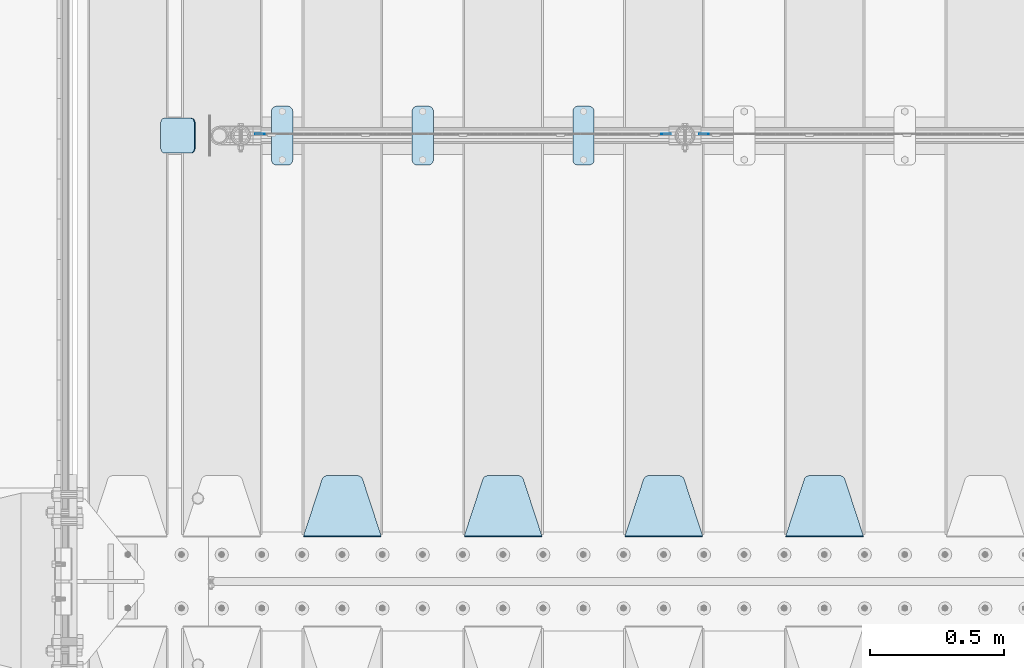
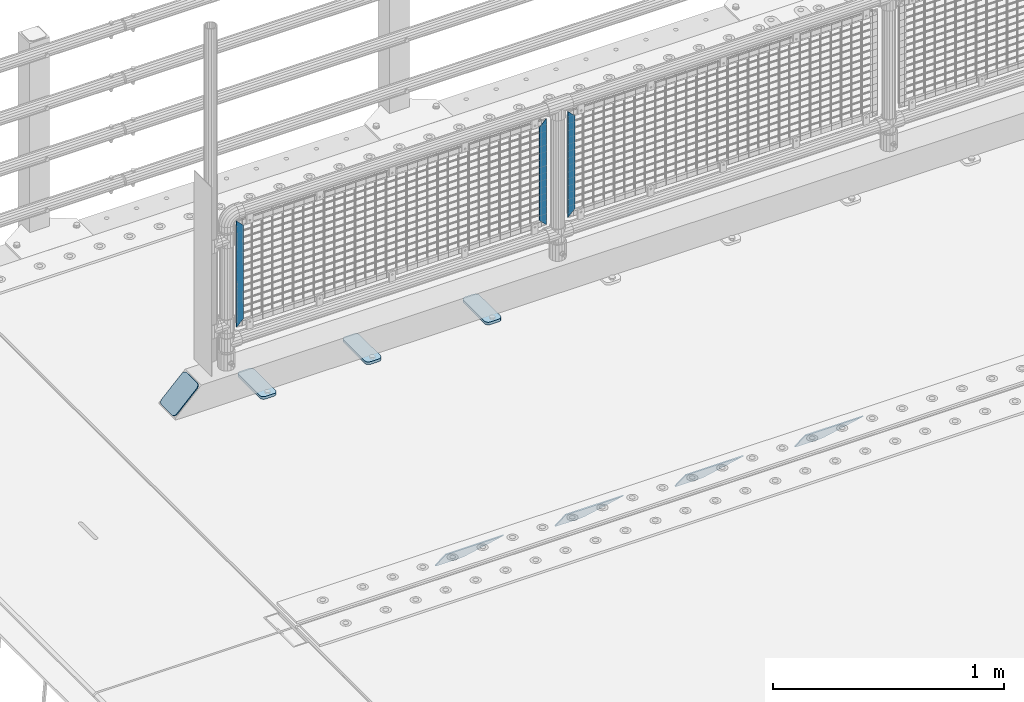
# One storey, part 158 of 193: 11 plates.
"""IFC2X3 building model written with IfcOpenShell, lengths in millimetres."""

import ifcopenshell
import ifcopenshell.guid

model = None  # the IFC model being written
_history = None  # IfcOwnerHistory: only IFC2X3 demands one
_inside = {}  # id of a spatial element -> (the spatial element, [elements in it])
_under = {}  # id of a project, library or spatial element -> (it, [spatial elements below it])
_declared = {}  # id of a project -> (the project, [libraries it declares])
_typed = {}  # id of a type object -> (the type object, [elements of that type])
_made_of = {}  # id of a material, layer set ... -> (it, [elements and type objects made of it])


def new_model(schema):
    """Start an empty IFC model of exactly this schema.

    Asked for "IFC4X3", IfcOpenShell would pick the latest addendum, in which some entities
    have other attributes; the version numbers below select the first issue.
    IFC2X3 requires an IfcOwnerHistory on every rooted entity: one is made here for all.
    """
    global model, _history
    if schema == "IFC4X3":
        model = ifcopenshell.file(schema_version=(4, 3, 0, 0))
    else:
        model = ifcopenshell.file(schema=schema)
    _inside.clear()
    _under.clear()
    _declared.clear()
    _typed.clear()
    _made_of.clear()
    _history = None
    if model.schema == "IFC2X3":
        org = make("IfcOrganization", Name="unknown")
        user = make(
            "IfcPersonAndOrganization",
            ThePerson=make("IfcPerson", FamilyName="unknown"),
            TheOrganization=org,
        )
        app = make(
            "IfcApplication",
            ApplicationDeveloper=org,
            Version="unknown",
            ApplicationFullName="unknown",
            ApplicationIdentifier="unknown",
        )
        _history = make(
            "IfcOwnerHistory",
            OwningUser=user,
            OwningApplication=app,
            ChangeAction="ADDED",
            CreationDate=0,
        )
    return model


def make(cls, **values):
    """One entity of the class cls with the attributes given. An attribute that is None is left unset."""
    return model.create_entity(
        cls, **{name: value for name, value in values.items() if value is not None}
    )


def rooted(cls, **values):
    """An entity with a GlobalId (a new one), such as an element, a storey or a relation."""
    return make(cls, GlobalId=ifcopenshell.guid.new(), OwnerHistory=_history, **values)


def si_unit(unit_type, name, prefix=None):
    """IfcSIUnit, for example si_unit("LENGTHUNIT", "METRE", prefix="MILLI")."""
    return make("IfcSIUnit", UnitType=unit_type, Prefix=prefix, Name=name)


def assignment(units):
    """IfcUnitAssignment: the units of a project."""
    return None if units is None else make("IfcUnitAssignment", Units=units)


def point(xyz):
    """IfcCartesianPoint."""
    return None if xyz is None else make("IfcCartesianPoint", Coordinates=xyz)


def direction(xyz):
    """IfcDirection."""
    return None if xyz is None else make("IfcDirection", DirectionRatios=xyz)


def frame(location, z_axis=None, x_axis=None):
    """IfcAxis2Placement3D, a coordinate frame: its origin and axes. An axis left out is left unset."""
    return make(
        "IfcAxis2Placement3D",
        Location=point(location),
        Axis=direction(z_axis),
        RefDirection=direction(x_axis),
    )


def origin_with_axes():
    """The frame at (0, 0, 0) with the z axis (0, 0, 1) and the x axis (1, 0, 0) written out."""
    return frame((0.0, 0.0, 0.0), z_axis=(0.0, 0.0, 1.0), x_axis=(1.0, 0.0, 0.0))


def place(relative_to, where):
    """IfcLocalPlacement: puts the frame where relative to a parent placement (None: the world)."""
    return make(
        "IfcLocalPlacement", PlacementRelTo=relative_to, RelativePlacement=where
    )


def context(
    kind, dimensions, precision=None, world=None, true_north=None, identifier=None
):
    """IfcGeometricRepresentationContext, for example the 3D "Model" context."""
    return make(
        "IfcGeometricRepresentationContext",
        ContextIdentifier=identifier,
        ContextType=kind,
        CoordinateSpaceDimension=dimensions,
        Precision=precision,
        WorldCoordinateSystem=world,
        TrueNorth=true_north,
    )


def subcontext(parent, identifier, kind, view, scale=None):
    """IfcGeometricRepresentationSubContext, for example "Body" below "Model"."""
    return make(
        "IfcGeometricRepresentationSubContext",
        ContextIdentifier=identifier,
        ContextType=kind,
        ParentContext=parent,
        TargetScale=scale,
        TargetView=view,
    )


def project(units=None, contexts=None):
    """IfcProject with its units and contexts."""
    return rooted(
        "IfcProject",
        Name="project",
        RepresentationContexts=contexts,
        UnitsInContext=assignment(units),
    )


def spatial(cls, under=None, at=None, **own):
    """A site, building, storey or space (cls), placed at a placement, below another one or the project."""
    s = rooted(cls, ObjectPlacement=at, **own)
    if under is not None:
        _under.setdefault(under.id(), (under, []))[1].append(s)
    return s


def faces_of(points, faces, orient=None, outer=None):
    """IfcFace entities. A face is a list of loops; a loop is a list of indices into points, from 0.

    orient and outer hold one flag for each loop. By default every Orientation is true, the
    first loop of a face is its IfcFaceOuterBound and the others are IfcFaceBound.
    """
    made = []
    for i, loops in enumerate(faces):
        bounds = []
        for j, loop in enumerate(loops):
            is_outer = j == 0 if outer is None else outer[i][j]
            bounds.append(
                make(
                    "IfcFaceOuterBound" if is_outer else "IfcFaceBound",
                    Bound=make("IfcPolyLoop", Polygon=[points[k] for k in loop]),
                    Orientation=True if orient is None else orient[i][j],
                )
            )
        made.append(make("IfcFace", Bounds=bounds))
    return made


def faceted_brep(points, faces, orient=None, outer=None, voids=None):
    """IfcFacetedBrep: a solid bounded by flat faces; with voids (closed shells), ...WithVoids."""
    shared = [point(p) for p in points]
    hull = make("IfcClosedShell", CfsFaces=faces_of(shared, faces, orient, outer))
    if voids is None:
        return make("IfcFacetedBrep", Outer=hull)
    return make(
        "IfcFacetedBrepWithVoids",
        Outer=hull,
        Voids=[
            make(cls, CfsFaces=faces_of(shared, fs, o, b)) for cls, fs, o, b in voids
        ],
    )


def shape(context_of_items, identifier, shape_type, items):
    """IfcShapeRepresentation: the items that make up one representation, for example the "Body"."""
    return make(
        "IfcShapeRepresentation",
        ContextOfItems=context_of_items,
        RepresentationIdentifier=identifier,
        RepresentationType=shape_type,
        Items=items,
    )


def material(Name=None, Category=None):
    """IfcMaterial."""
    return make("IfcMaterial", Name=Name, Category=Category)


def made_of(thing, what):
    """Note that an element or type object is made of a material, layer set ...; save() writes the relation."""
    if what is not None:
        _made_of.setdefault(what.id(), (what, []))[1].append(thing)
    return thing


def type_object(cls, material=None, **own):
    """A type object (cls), such as IfcWallType, which elements share."""
    return made_of(rooted(cls, **own), material)


def element(
    cls,
    number,
    at=None,
    inside=None,
    cuts=None,
    type_object=None,
    material=None,
    context=None,
    identifier="Body",
    shape_type=None,
    held_by="IfcProductDefinitionShape",
    body=None,
    shapes=None,
    **own,
):
    """One element of the class cls, such as IfcWall. Its Tag is "e" and its number.

    at: its placement. inside: the storey or other place that contains it. cuts: it is an
    opening in that element (IfcRelVoidsElement). A single representation is given by context,
    identifier, shape_type and body (its items); several are given by shapes. held_by: the class
    of the entity that holds the representations. save() writes the other relations.
    """
    e = rooted(cls, Tag="e%d" % number, ObjectPlacement=at, **own)
    if body is not None:
        shapes = [shape(context, identifier, shape_type, body)]
    if shapes is not None:
        e.Representation = make(held_by, Representations=shapes)
    if inside is not None:
        _inside.setdefault(inside.id(), (inside, []))[1].append(e)
    if cuts is not None:
        rooted(
            "IfcRelVoidsElement", RelatingBuildingElement=cuts, RelatedOpeningElement=e
        )
    if type_object is not None:
        _typed.setdefault(type_object.id(), (type_object, []))[1].append(e)
    return made_of(e, material)


def aggregate(whole, parts):
    """IfcRelAggregates: a whole, such as a stair, and the parts it consists of."""
    return rooted("IfcRelAggregates", RelatingObject=whole, RelatedObjects=parts)


def save(model, path):
    """Write the relations noted so far, then the file.

    IfcRelAggregates (storeys below a building ...), IfcRelContainedInSpatialStructure (elements
    in a storey), IfcRelDefinesByType, IfcRelAssociatesMaterial and IfcRelDeclares: one each for
    every whole, place, type object, material and project.
    """
    for whole, parts in _under.values():
        aggregate(whole, parts)
    for where, things in _inside.values():
        rooted(
            "IfcRelContainedInSpatialStructure",
            RelatedElements=things,
            RelatingStructure=where,
        )
    for kind, things in _typed.values():
        rooted("IfcRelDefinesByType", RelatedObjects=things, RelatingType=kind)
    for what, things in _made_of.values():
        rooted("IfcRelAssociatesMaterial", RelatedObjects=things, RelatingMaterial=what)
    for by, libraries in _declared.values():
        rooted("IfcRelDeclares", RelatingContext=by, RelatedDefinitions=libraries)
    model.write(path)


model = new_model("IFC2X3")

# Units and contexts
model_context = context("Model", 3, precision=1e-05, world=origin_with_axes())
body_context = subcontext(model_context, "Body", "Model", "MODEL_VIEW")
ifc_project = project(units=[si_unit("LENGTHUNIT", "METRE", prefix="MILLI"), si_unit("AREAUNIT", "SQUARE_METRE"), si_unit("VOLUMEUNIT", "CUBIC_METRE"), si_unit("MASSUNIT", "GRAM", prefix="KILO"), si_unit("TIMEUNIT", "SECOND"), si_unit("PLANEANGLEUNIT", "RADIAN"), si_unit("SOLIDANGLEUNIT", "STERADIAN"), si_unit("THERMODYNAMICTEMPERATUREUNIT", "DEGREE_CELSIUS"), si_unit("LUMINOUSINTENSITYUNIT", "LUMEN")], contexts=[model_context])

# Site, building, storey
site_placement = place(None, origin_with_axes())
site = spatial("IfcSite", under=ifc_project, at=site_placement, CompositionType="ELEMENT")
building_placement = place(site_placement, origin_with_axes())
building = spatial("IfcBuilding", under=site, at=building_placement, Name="Standard", CompositionType="ELEMENT")
storey_placement = place(building_placement, origin_with_axes())
storey = spatial("IfcBuildingStorey", under=building, at=storey_placement, Name="Undefined", CompositionType="ELEMENT", Elevation=0.0)

# Plates
ifc_material_1 = material(Name="STEEL/S355N")
plate_type_1 = type_object("IfcPlateType", PredefinedType="NOTDEFINED")
plate_1_placement = place(storey_placement, frame((-39505.0, 27168.232233047, -1.76776695296758), z_axis=(0.0, 0.707106781186547, -0.707106781186548), x_axis=(-1.0, 0.0, 0.0)))
element("IfcPlate", 1, at=plate_1_placement, inside=storey, type_object=plate_type_1, material=ifc_material_1, context=body_context, shape_type="Brep", body=[
    faceted_brep([(0.0, -2.5, 0.0), (69.345504679477, -2.50000000000364, 300.171731424831), (69.345504679477, 2.49999999999636, 300.171731424831), (0.0, 2.5, 0.0), (70.9274061199576, -2.50000000000364, 304.897442415397), (70.9274061199576, 2.49999999999636, 304.897442415397), (73.3818627772307, -2.50000000000364, 309.234538108529), (73.3818627772307, 2.49999999999636, 309.234538108529), (76.6187032999551, -2.50000000000728, 313.023683126103), (76.6187032999551, 2.49999999999636, 313.023683126103), (80.5190132704993, -2.50000000000364, 316.125672595372), (80.5190132704993, 2.49999999999636, 316.125672595368), (84.9395038596849, -2.50000000000364, 318.426546230472), (84.9395038596849, 2.49999999999636, 318.426546230476), (89.7177759439219, -2.50000000000364, 319.841774983273), (89.7177759439219, 2.49999999999636, 319.841774983277), (94.678286292652, -2.50000000000364, 320.319366455074), (94.678286292652, 2.49999999999636, 320.319366455074), (195.321713707348, -2.50000000000364, 320.319366455074), (195.321713707348, 2.49999999999636, 320.319366455074), (200.282224056078, -2.50000000000364, 319.841774983273), (200.282224056078, 2.49999999999636, 319.841774983277), (205.060496140315, -2.50000000000364, 318.426546230472), (205.060496140315, 2.49999999999636, 318.426546230472), (209.480986729501, -2.50000000000364, 316.125672595372), (209.480986729501, 2.49999999999636, 316.125672595368), (213.381296700045, -2.50000000000728, 313.023683126103), (213.381296700045, 2.49999999999272, 313.023683126103), (216.618137222769, -2.50000000000364, 309.234538108525), (216.618137222769, 2.49999999999636, 309.234538108522), (219.072593880042, -2.50000000000364, 304.897442415397), (219.072593880042, 2.49999999999636, 304.897442415397), (220.654495320523, -2.50000000000364, 300.171731424831), (220.654495320523, 2.49999999999636, 300.171731424831), (290.0, -2.50000000000364, 0.0), (290.0, 2.49999999999636, 0.0)], [[[0, 1, 2, 3]], [[1, 4, 5, 2]], [[4, 6, 7, 5]], [[6, 8, 9, 7]], [[8, 10, 11, 9]], [[10, 12, 13, 11]], [[12, 14, 15, 13]], [[14, 16, 17, 15]], [[16, 18, 19, 17]], [[18, 20, 21, 19]], [[20, 22, 23, 21]], [[22, 24, 25, 23]], [[24, 26, 27, 25]], [[26, 28, 29, 27]], [[28, 30, 31, 29]], [[30, 32, 33, 31]], [[32, 34, 35, 33]], [[34, 0, 3, 35]], [[5, 7, 9, 11, 13, 15, 17, 19, 21, 23, 25, 27, 29, 31, 33, 35, 3, 2]], [[34, 32, 30, 28, 26, 24, 22, 20, 18, 16, 14, 12, 10, 8, 6, 4, 1, 0]]]),
])
plate_2_placement = place(storey_placement, frame((-40105.0, 27168.232233047, -1.76776695296758), z_axis=(0.0, 0.707106781186547, -0.707106781186548), x_axis=(-1.0, 0.0, 0.0)))
element("IfcPlate", 2, at=plate_2_placement, inside=storey, type_object=plate_type_1, material=ifc_material_1, context=body_context, shape_type="Brep", body=[
    faceted_brep([(0.0, -2.5, 0.0), (69.345504679477, -2.50000000000364, 300.171731424831), (69.345504679477, 2.49999999999636, 300.171731424831), (0.0, 2.5, 0.0), (70.9274061199576, -2.50000000000364, 304.897442415397), (70.9274061199576, 2.49999999999636, 304.897442415397), (73.3818627772307, -2.50000000000364, 309.234538108529), (73.3818627772307, 2.49999999999636, 309.234538108529), (76.6187032999551, -2.50000000000728, 313.023683126103), (76.6187032999551, 2.49999999999636, 313.023683126103), (80.5190132704993, -2.50000000000364, 316.125672595372), (80.5190132704993, 2.49999999999636, 316.125672595368), (84.9395038596849, -2.50000000000364, 318.426546230472), (84.9395038596849, 2.49999999999636, 318.426546230476), (89.7177759439219, -2.50000000000364, 319.841774983273), (89.7177759439219, 2.49999999999636, 319.841774983277), (94.678286292652, -2.50000000000364, 320.319366455074), (94.678286292652, 2.49999999999636, 320.319366455074), (195.321713707348, -2.50000000000364, 320.319366455074), (195.321713707348, 2.49999999999636, 320.319366455074), (200.282224056078, -2.50000000000364, 319.841774983273), (200.282224056078, 2.49999999999636, 319.841774983277), (205.060496140315, -2.50000000000364, 318.426546230472), (205.060496140315, 2.49999999999636, 318.426546230472), (209.480986729501, -2.50000000000364, 316.125672595372), (209.480986729501, 2.49999999999636, 316.125672595368), (213.381296700045, -2.50000000000728, 313.023683126103), (213.381296700045, 2.49999999999272, 313.023683126103), (216.618137222769, -2.50000000000364, 309.234538108525), (216.618137222769, 2.49999999999636, 309.234538108522), (219.072593880042, -2.50000000000364, 304.897442415397), (219.072593880042, 2.49999999999636, 304.897442415397), (220.654495320523, -2.50000000000364, 300.171731424831), (220.654495320523, 2.49999999999636, 300.171731424831), (290.0, -2.50000000000364, 0.0), (290.0, 2.49999999999636, 0.0)], [[[0, 1, 2, 3]], [[1, 4, 5, 2]], [[4, 6, 7, 5]], [[6, 8, 9, 7]], [[8, 10, 11, 9]], [[10, 12, 13, 11]], [[12, 14, 15, 13]], [[14, 16, 17, 15]], [[16, 18, 19, 17]], [[18, 20, 21, 19]], [[20, 22, 23, 21]], [[22, 24, 25, 23]], [[24, 26, 27, 25]], [[26, 28, 29, 27]], [[28, 30, 31, 29]], [[30, 32, 33, 31]], [[32, 34, 35, 33]], [[34, 0, 3, 35]], [[5, 7, 9, 11, 13, 15, 17, 19, 21, 23, 25, 27, 29, 31, 33, 35, 3, 2]], [[34, 32, 30, 28, 26, 24, 22, 20, 18, 16, 14, 12, 10, 8, 6, 4, 1, 0]]]),
])
plate_3_placement = place(storey_placement, frame((-40705.0, 27168.232233047, -1.76776695296758), z_axis=(0.0, 0.707106781186547, -0.707106781186548), x_axis=(-1.0, 0.0, 0.0)))
element("IfcPlate", 3, at=plate_3_placement, inside=storey, type_object=plate_type_1, material=ifc_material_1, context=body_context, shape_type="Brep", body=[
    faceted_brep([(0.0, -2.5, 0.0), (69.345504679477, -2.50000000000364, 300.171731424831), (69.345504679477, 2.49999999999636, 300.171731424831), (0.0, 2.5, 0.0), (70.9274061199576, -2.50000000000364, 304.897442415397), (70.9274061199576, 2.49999999999636, 304.897442415397), (73.3818627772307, -2.50000000000364, 309.234538108529), (73.3818627772307, 2.49999999999636, 309.234538108529), (76.6187032999551, -2.50000000000728, 313.023683126103), (76.6187032999551, 2.49999999999636, 313.023683126103), (80.5190132704993, -2.50000000000364, 316.125672595372), (80.5190132704993, 2.49999999999636, 316.125672595368), (84.9395038596849, -2.50000000000364, 318.426546230472), (84.9395038596849, 2.49999999999636, 318.426546230476), (89.7177759439219, -2.50000000000364, 319.841774983273), (89.7177759439219, 2.49999999999636, 319.841774983277), (94.678286292652, -2.50000000000364, 320.319366455074), (94.678286292652, 2.49999999999636, 320.319366455074), (195.321713707348, -2.50000000000364, 320.319366455074), (195.321713707348, 2.49999999999636, 320.319366455074), (200.282224056078, -2.50000000000364, 319.841774983273), (200.282224056078, 2.49999999999636, 319.841774983277), (205.060496140315, -2.50000000000364, 318.426546230472), (205.060496140315, 2.49999999999636, 318.426546230472), (209.480986729501, -2.50000000000364, 316.125672595372), (209.480986729501, 2.49999999999636, 316.125672595368), (213.381296700045, -2.50000000000728, 313.023683126103), (213.381296700045, 2.49999999999272, 313.023683126103), (216.618137222769, -2.50000000000364, 309.234538108525), (216.618137222769, 2.49999999999636, 309.234538108522), (219.072593880042, -2.50000000000364, 304.897442415397), (219.072593880042, 2.49999999999636, 304.897442415397), (220.654495320523, -2.50000000000364, 300.171731424831), (220.654495320523, 2.49999999999636, 300.171731424831), (290.0, -2.50000000000364, 0.0), (290.0, 2.49999999999636, 0.0)], [[[0, 1, 2, 3]], [[1, 4, 5, 2]], [[4, 6, 7, 5]], [[6, 8, 9, 7]], [[8, 10, 11, 9]], [[10, 12, 13, 11]], [[12, 14, 15, 13]], [[14, 16, 17, 15]], [[16, 18, 19, 17]], [[18, 20, 21, 19]], [[20, 22, 23, 21]], [[22, 24, 25, 23]], [[24, 26, 27, 25]], [[26, 28, 29, 27]], [[28, 30, 31, 29]], [[30, 32, 33, 31]], [[32, 34, 35, 33]], [[34, 0, 3, 35]], [[5, 7, 9, 11, 13, 15, 17, 19, 21, 23, 25, 27, 29, 31, 33, 35, 3, 2]], [[34, 32, 30, 28, 26, 24, 22, 20, 18, 16, 14, 12, 10, 8, 6, 4, 1, 0]]]),
])
plate_4_placement = place(storey_placement, frame((-41305.0, 27168.232233047, -1.76776695296758), z_axis=(0.0, 0.707106781186547, -0.707106781186548), x_axis=(-1.0, 0.0, 0.0)))
element("IfcPlate", 4, at=plate_4_placement, inside=storey, type_object=plate_type_1, material=ifc_material_1, context=body_context, shape_type="Brep", body=[
    faceted_brep([(0.0, -2.5, 0.0), (69.345504679477, -2.50000000000364, 300.171731424831), (69.345504679477, 2.49999999999636, 300.171731424831), (0.0, 2.5, 0.0), (70.9274061199576, -2.50000000000364, 304.897442415397), (70.9274061199576, 2.49999999999636, 304.897442415397), (73.3818627772307, -2.50000000000364, 309.234538108529), (73.3818627772307, 2.49999999999636, 309.234538108529), (76.6187032999551, -2.50000000000728, 313.023683126103), (76.6187032999551, 2.49999999999636, 313.023683126103), (80.5190132704993, -2.50000000000364, 316.125672595372), (80.5190132704993, 2.49999999999636, 316.125672595368), (84.9395038596849, -2.50000000000364, 318.426546230472), (84.9395038596849, 2.49999999999636, 318.426546230476), (89.7177759439219, -2.50000000000364, 319.841774983273), (89.7177759439219, 2.49999999999636, 319.841774983277), (94.678286292652, -2.50000000000364, 320.319366455074), (94.678286292652, 2.49999999999636, 320.319366455074), (195.321713707348, -2.50000000000364, 320.319366455074), (195.321713707348, 2.49999999999636, 320.319366455074), (200.282224056078, -2.50000000000364, 319.841774983273), (200.282224056078, 2.49999999999636, 319.841774983277), (205.060496140315, -2.50000000000364, 318.426546230472), (205.060496140315, 2.49999999999636, 318.426546230472), (209.480986729501, -2.50000000000364, 316.125672595372), (209.480986729501, 2.49999999999636, 316.125672595368), (213.381296700045, -2.50000000000728, 313.023683126103), (213.381296700045, 2.49999999999272, 313.023683126103), (216.618137222769, -2.50000000000364, 309.234538108525), (216.618137222769, 2.49999999999636, 309.234538108522), (219.072593880042, -2.50000000000364, 304.897442415397), (219.072593880042, 2.49999999999636, 304.897442415397), (220.654495320523, -2.50000000000364, 300.171731424831), (220.654495320523, 2.49999999999636, 300.171731424831), (290.0, -2.50000000000364, 0.0), (290.0, 2.49999999999636, 0.0)], [[[0, 1, 2, 3]], [[1, 4, 5, 2]], [[4, 6, 7, 5]], [[6, 8, 9, 7]], [[8, 10, 11, 9]], [[10, 12, 13, 11]], [[12, 14, 15, 13]], [[14, 16, 17, 15]], [[16, 18, 19, 17]], [[18, 20, 21, 19]], [[20, 22, 23, 21]], [[22, 24, 25, 23]], [[24, 26, 27, 25]], [[26, 28, 29, 27]], [[28, 30, 31, 29]], [[30, 32, 33, 31]], [[32, 34, 35, 33]], [[34, 0, 3, 35]], [[5, 7, 9, 11, 13, 15, 17, 19, 21, 23, 25, 27, 29, 31, 33, 35, 3, 2]], [[34, 32, 30, 28, 26, 24, 22, 20, 18, 16, 14, 12, 10, 8, 6, 4, 1, 0]]]),
])
ifc_material_2 = material(Name="Misc_Undefined")
plate_type_2 = type_object("IfcPlateType", PredefinedType="NOTDEFINED")
for number, where, z_axis, x_axis in (
    (5, (-40082.490286459, 28670.5, 879.519963133601), (-0.707008801899319, 0.0, -0.707204746899291), (-0.70720474689929, 0.0, 0.707008801899319)),
    (6, (-41740.490286459, 28670.5, 879.519963133601), (-0.707008801899319, 0.0, -0.707204746899291), (-0.70720474689929, 0.0, 0.707008801899319)),
):
    element("IfcPlate", number, at=place(storey_placement, frame(where, z_axis=z_axis, x_axis=x_axis)), inside=storey, type_object=plate_type_2, material=ifc_material_2, context=body_context, shape_type="Brep", body=[
        faceted_brep([(0.0, -1.49999999999636, 3.63797880709171e-12), (-348.552185058594, -1.5, 348.655029296875), (-348.552185058594, 1.5, 348.655029296875), (0.0, 1.50000000000364, 7.27595761418343e-12), (-348.544891357422, -1.5, 398.152496337891), (-348.544891357422, 1.5, 398.152496337891), (49.50439453125, -1.5, 7.6397554948926e-11), (49.50439453125, 1.5, 7.6397554948926e-11)], [[[0, 1, 2, 3]], [[1, 4, 5, 2]], [[4, 6, 7, 5]], [[6, 0, 3, 7]], [[5, 7, 3, 2]], [[6, 4, 1, 0]]]),
    ])
plate_5_placement = place(storey_placement, frame((-40259.5003125164, 28670.5, 879.52), z_axis=(0.707103624179499, 0.0, -0.707109938179501), x_axis=(0.707109938179495, 0.0, 0.707103624179505)))
element("IfcPlate", 7, at=plate_5_placement, inside=storey, type_object=plate_type_2, material=ifc_material_2, context=body_context, shape_type="Brep", body=[
    faceted_brep([(0.0, -1.49999999999636, 3.63797880709171e-12), (-348.605163574215, -1.5, 348.602081298824), (-348.605163574215, 1.5, 348.602081298824), (0.0, 1.50000000000364, 7.27595761418343e-12), (-348.605163574215, -1.5, 398.099334716793), (-348.605163574215, 1.5, 398.099334716793), (49.4976959228552, -1.5, -1.01863406598568e-10), (49.4976959228552, 1.5, -1.01863406598568e-10)], [[[0, 1, 2, 3]], [[1, 4, 5, 2]], [[4, 6, 7, 5]], [[6, 0, 3, 7]], [[5, 7, 3, 2]], [[6, 4, 1, 0]]]),
])
ifc_material_3 = material(Name="STEEL/S355J2")
plate_type_3 = type_object("IfcPlateType", PredefinedType="NOTDEFINED")
plate_6_placement = place(storey_placement, frame((-40590.0, 28774.5, 21.0199999999977), z_axis=(1.0, 0.0, 0.0), x_axis=(0.0, -1.0, 0.0)))
element("IfcPlate", 8, at=plate_6_placement, inside=storey, type_object=plate_type_3, material=ifc_material_3, context=body_context, shape_type="Brep", body=[
    faceted_brep([(0.0, -7.0, 20.0), (0.0, -7.0, 60.0), (0.0, 7.0, 60.0), (0.0, 7.0, 20.0), (0.384294391937146, -7.0, 63.9018064403208), (0.384294391937146, 7.0, 63.9018064403208), (1.52240934977453, -7.0, 67.6536686473009), (1.52240934977453, 7.0, 67.6536686473009), (3.37060775395003, -7.0, 71.1114046603907), (3.37060775395003, 7.0, 71.1114046603907), (5.8578643762703, -7.0, 74.1421356237297), (5.8578643762703, 7.0, 74.1421356237297), (8.88859533960931, -7.0, 76.62939224605), (8.88859533960931, 7.0, 76.62939224605), (12.3463313526991, -7.0, 78.4775906502255), (12.3463313526991, 7.0, 78.4775906502255), (16.0981935596792, -7.0, 79.6157056080629), (16.0981935596792, 7.0, 79.6157056080629), (20.0, -7.0, 80.0), (20.0, 7.0, 80.0), (200.0, -7.0, 80.0), (200.0, 7.0, 80.0), (203.901806440321, -7.0, 79.6157056080629), (203.901806440321, 7.0, 79.6157056080629), (207.653668647301, -7.0, 78.4775906502255), (207.653668647301, 7.0, 78.4775906502255), (211.111404660391, -7.0, 76.62939224605), (211.111404660391, 7.0, 76.62939224605), (214.14213562373, -7.0, 74.1421356237297), (214.14213562373, 7.0, 74.1421356237297), (216.62939224605, -7.0, 71.1114046603907), (216.62939224605, 7.0, 71.1114046603907), (218.477590650225, -7.0, 67.6536686473009), (218.477590650225, 7.0, 67.6536686473009), (219.615705608063, -7.0, 63.9018064403208), (219.615705608063, 7.0, 63.9018064403208), (220.0, -7.0, 60.0), (220.0, 7.0, 60.0), (220.0, -7.0, 20.0), (220.0, 7.0, 20.0), (219.615705608063, -7.0, 16.0981935596792), (219.615705608063, 7.0, 16.0981935596792), (218.477590650225, -7.0, 12.3463313526991), (218.477590650225, 7.0, 12.3463313526991), (216.62939224605, -7.0, 8.88859533960931), (216.62939224605, 7.0, 8.88859533960931), (214.14213562373, -7.0, 5.8578643762703), (214.14213562373, 7.0, 5.8578643762703), (211.111404660391, -7.0, 3.37060775395003), (211.111404660391, 7.0, 3.37060775395003), (207.653668647301, -7.0, 1.52240934977453), (207.653668647301, 7.0, 1.52240934977453), (203.901806440321, -7.0, 0.384294391937146), (203.901806440321, 7.0, 0.384294391937146), (200.0, -7.0, 0.0), (200.0, 7.0, 0.0), (20.0, -7.0, 0.0), (20.0, 7.0, 0.0), (16.0981935596792, -7.0, 0.384294391937146), (16.0981935596792, 7.0, 0.384294391937146), (12.3463313526991, -7.0, 1.52240934977453), (12.3463313526991, 7.0, 1.52240934977453), (8.88859533960931, -7.0, 3.37060775395003), (8.88859533960931, 7.0, 3.37060775395003), (5.8578643762703, -7.0, 5.8578643762703), (5.8578643762703, 7.0, 5.8578643762703), (3.37060775395003, -7.0, 8.88859533960931), (3.37060775395003, 7.0, 8.88859533960931), (1.52240934977453, -7.0, 12.3463313526991), (1.52240934977453, 7.0, 12.3463313526991), (0.384294391937146, -7.0, 16.0981935596792), (0.384294391937146, 7.0, 16.0981935596792)], [[[0, 1, 2, 3]], [[1, 4, 5, 2]], [[4, 6, 7, 5]], [[6, 8, 9, 7]], [[8, 10, 11, 9]], [[10, 12, 13, 11]], [[12, 14, 15, 13]], [[14, 16, 17, 15]], [[16, 18, 19, 17]], [[18, 20, 21, 19]], [[20, 22, 23, 21]], [[22, 24, 25, 23]], [[24, 26, 27, 25]], [[26, 28, 29, 27]], [[28, 30, 31, 29]], [[30, 32, 33, 31]], [[32, 34, 35, 33]], [[34, 36, 37, 35]], [[36, 38, 39, 37]], [[38, 40, 41, 39]], [[40, 42, 43, 41]], [[42, 44, 45, 43]], [[44, 46, 47, 45]], [[46, 48, 49, 47]], [[48, 50, 51, 49]], [[50, 52, 53, 51]], [[52, 54, 55, 53]], [[54, 56, 57, 55]], [[56, 58, 59, 57]], [[58, 60, 61, 59]], [[60, 62, 63, 61]], [[62, 64, 65, 63]], [[64, 66, 67, 65]], [[66, 68, 69, 67]], [[68, 70, 71, 69]], [[70, 0, 3, 71]], [[5, 7, 9, 11, 13, 15, 17, 19, 21, 23, 25, 27, 29, 31, 33, 35, 37, 39, 41, 43, 45, 47, 49, 51, 53, 55, 57, 59, 61, 63, 65, 67, 69, 71, 3, 2]], [[70, 68, 66, 64, 62, 60, 58, 56, 54, 52, 50, 48, 46, 44, 42, 40, 38, 36, 34, 32, 30, 28, 26, 24, 22, 20, 18, 16, 14, 12, 10, 8, 6, 4, 1, 0]]]),
])
plate_7_placement = place(storey_placement, frame((-41190.0, 28774.5, 21.0199999999977), z_axis=(1.0, 0.0, 0.0), x_axis=(0.0, -1.0, 0.0)))
element("IfcPlate", 9, at=plate_7_placement, inside=storey, type_object=plate_type_3, material=ifc_material_3, context=body_context, shape_type="Brep", body=[
    faceted_brep([(0.0, -7.0, 20.0), (0.0, -7.0, 60.0), (0.0, 7.0, 60.0), (0.0, 7.0, 20.0), (0.384294391937146, -7.0, 63.9018064403208), (0.384294391937146, 7.0, 63.9018064403208), (1.52240934977453, -7.0, 67.6536686473009), (1.52240934977453, 7.0, 67.6536686473009), (3.37060775395003, -7.0, 71.1114046603907), (3.37060775395003, 7.0, 71.1114046603907), (5.8578643762703, -7.0, 74.1421356237297), (5.8578643762703, 7.0, 74.1421356237297), (8.88859533960931, -7.0, 76.62939224605), (8.88859533960931, 7.0, 76.62939224605), (12.3463313526991, -7.0, 78.4775906502255), (12.3463313526991, 7.0, 78.4775906502255), (16.0981935596792, -7.0, 79.6157056080629), (16.0981935596792, 7.0, 79.6157056080629), (20.0, -7.0, 80.0), (20.0, 7.0, 80.0), (200.0, -7.0, 80.0), (200.0, 7.0, 80.0), (203.901806440321, -7.0, 79.6157056080629), (203.901806440321, 7.0, 79.6157056080629), (207.653668647301, -7.0, 78.4775906502255), (207.653668647301, 7.0, 78.4775906502255), (211.111404660391, -7.0, 76.62939224605), (211.111404660391, 7.0, 76.62939224605), (214.14213562373, -7.0, 74.1421356237297), (214.14213562373, 7.0, 74.1421356237297), (216.62939224605, -7.0, 71.1114046603907), (216.62939224605, 7.0, 71.1114046603907), (218.477590650225, -7.0, 67.6536686473009), (218.477590650225, 7.0, 67.6536686473009), (219.615705608063, -7.0, 63.9018064403208), (219.615705608063, 7.0, 63.9018064403208), (220.0, -7.0, 60.0), (220.0, 7.0, 60.0), (220.0, -7.0, 20.0), (220.0, 7.0, 20.0), (219.615705608063, -7.0, 16.0981935596792), (219.615705608063, 7.0, 16.0981935596792), (218.477590650225, -7.0, 12.3463313526991), (218.477590650225, 7.0, 12.3463313526991), (216.62939224605, -7.0, 8.88859533960931), (216.62939224605, 7.0, 8.88859533960931), (214.14213562373, -7.0, 5.8578643762703), (214.14213562373, 7.0, 5.8578643762703), (211.111404660391, -7.0, 3.37060775395003), (211.111404660391, 7.0, 3.37060775395003), (207.653668647301, -7.0, 1.52240934977453), (207.653668647301, 7.0, 1.52240934977453), (203.901806440321, -7.0, 0.384294391937146), (203.901806440321, 7.0, 0.384294391937146), (200.0, -7.0, 0.0), (200.0, 7.0, 0.0), (20.0, -7.0, 0.0), (20.0, 7.0, 0.0), (16.0981935596792, -7.0, 0.384294391937146), (16.0981935596792, 7.0, 0.384294391937146), (12.3463313526991, -7.0, 1.52240934977453), (12.3463313526991, 7.0, 1.52240934977453), (8.88859533960931, -7.0, 3.37060775395003), (8.88859533960931, 7.0, 3.37060775395003), (5.8578643762703, -7.0, 5.8578643762703), (5.8578643762703, 7.0, 5.8578643762703), (3.37060775395003, -7.0, 8.88859533960931), (3.37060775395003, 7.0, 8.88859533960931), (1.52240934977453, -7.0, 12.3463313526991), (1.52240934977453, 7.0, 12.3463313526991), (0.384294391937146, -7.0, 16.0981935596792), (0.384294391937146, 7.0, 16.0981935596792)], [[[0, 1, 2, 3]], [[1, 4, 5, 2]], [[4, 6, 7, 5]], [[6, 8, 9, 7]], [[8, 10, 11, 9]], [[10, 12, 13, 11]], [[12, 14, 15, 13]], [[14, 16, 17, 15]], [[16, 18, 19, 17]], [[18, 20, 21, 19]], [[20, 22, 23, 21]], [[22, 24, 25, 23]], [[24, 26, 27, 25]], [[26, 28, 29, 27]], [[28, 30, 31, 29]], [[30, 32, 33, 31]], [[32, 34, 35, 33]], [[34, 36, 37, 35]], [[36, 38, 39, 37]], [[38, 40, 41, 39]], [[40, 42, 43, 41]], [[42, 44, 45, 43]], [[44, 46, 47, 45]], [[46, 48, 49, 47]], [[48, 50, 51, 49]], [[50, 52, 53, 51]], [[52, 54, 55, 53]], [[54, 56, 57, 55]], [[56, 58, 59, 57]], [[58, 60, 61, 59]], [[60, 62, 63, 61]], [[62, 64, 65, 63]], [[64, 66, 67, 65]], [[66, 68, 69, 67]], [[68, 70, 71, 69]], [[70, 0, 3, 71]], [[5, 7, 9, 11, 13, 15, 17, 19, 21, 23, 25, 27, 29, 31, 33, 35, 37, 39, 41, 43, 45, 47, 49, 51, 53, 55, 57, 59, 61, 63, 65, 67, 69, 71, 3, 2]], [[70, 68, 66, 64, 62, 60, 58, 56, 54, 52, 50, 48, 46, 44, 42, 40, 38, 36, 34, 32, 30, 28, 26, 24, 22, 20, 18, 16, 14, 12, 10, 8, 6, 4, 1, 0]]]),
])
plate_8_placement = place(storey_placement, frame((-41715.0, 28774.5, 21.0199999999977), z_axis=(1.0, 0.0, 0.0), x_axis=(0.0, -1.0, 0.0)))
element("IfcPlate", 10, at=plate_8_placement, inside=storey, type_object=plate_type_3, material=ifc_material_3, context=body_context, shape_type="Brep", body=[
    faceted_brep([(0.0, -7.0, 20.0), (0.0, -7.0, 60.0), (0.0, 7.0, 60.0), (0.0, 7.0, 20.0), (0.384294391937146, -7.0, 63.9018064403208), (0.384294391937146, 7.0, 63.9018064403208), (1.52240934977453, -7.0, 67.6536686473009), (1.52240934977453, 7.0, 67.6536686473009), (3.37060775395003, -7.0, 71.1114046603907), (3.37060775395003, 7.0, 71.1114046603907), (5.8578643762703, -7.0, 74.1421356237297), (5.8578643762703, 7.0, 74.1421356237297), (8.88859533960931, -7.0, 76.62939224605), (8.88859533960931, 7.0, 76.62939224605), (12.3463313526991, -7.0, 78.4775906502255), (12.3463313526991, 7.0, 78.4775906502255), (16.0981935596792, -7.0, 79.6157056080629), (16.0981935596792, 7.0, 79.6157056080629), (20.0, -7.0, 80.0), (20.0, 7.0, 80.0), (200.0, -7.0, 80.0), (200.0, 7.0, 80.0), (203.901806440321, -7.0, 79.6157056080629), (203.901806440321, 7.0, 79.6157056080629), (207.653668647301, -7.0, 78.4775906502255), (207.653668647301, 7.0, 78.4775906502255), (211.111404660391, -7.0, 76.62939224605), (211.111404660391, 7.0, 76.62939224605), (214.14213562373, -7.0, 74.1421356237297), (214.14213562373, 7.0, 74.1421356237297), (216.62939224605, -7.0, 71.1114046603907), (216.62939224605, 7.0, 71.1114046603907), (218.477590650225, -7.0, 67.6536686473009), (218.477590650225, 7.0, 67.6536686473009), (219.615705608063, -7.0, 63.9018064403208), (219.615705608063, 7.0, 63.9018064403208), (220.0, -7.0, 60.0), (220.0, 7.0, 60.0), (220.0, -7.0, 20.0), (220.0, 7.0, 20.0), (219.615705608063, -7.0, 16.0981935596792), (219.615705608063, 7.0, 16.0981935596792), (218.477590650225, -7.0, 12.3463313526991), (218.477590650225, 7.0, 12.3463313526991), (216.62939224605, -7.0, 8.88859533960931), (216.62939224605, 7.0, 8.88859533960931), (214.14213562373, -7.0, 5.8578643762703), (214.14213562373, 7.0, 5.8578643762703), (211.111404660391, -7.0, 3.37060775395003), (211.111404660391, 7.0, 3.37060775395003), (207.653668647301, -7.0, 1.52240934977453), (207.653668647301, 7.0, 1.52240934977453), (203.901806440321, -7.0, 0.384294391937146), (203.901806440321, 7.0, 0.384294391937146), (200.0, -7.0, 0.0), (200.0, 7.0, 0.0), (20.0, -7.0, 0.0), (20.0, 7.0, 0.0), (16.0981935596792, -7.0, 0.384294391937146), (16.0981935596792, 7.0, 0.384294391937146), (12.3463313526991, -7.0, 1.52240934977453), (12.3463313526991, 7.0, 1.52240934977453), (8.88859533960931, -7.0, 3.37060775395003), (8.88859533960931, 7.0, 3.37060775395003), (5.8578643762703, -7.0, 5.8578643762703), (5.8578643762703, 7.0, 5.8578643762703), (3.37060775395003, -7.0, 8.88859533960931), (3.37060775395003, 7.0, 8.88859533960931), (1.52240934977453, -7.0, 12.3463313526991), (1.52240934977453, 7.0, 12.3463313526991), (0.384294391937146, -7.0, 16.0981935596792), (0.384294391937146, 7.0, 16.0981935596792)], [[[0, 1, 2, 3]], [[1, 4, 5, 2]], [[4, 6, 7, 5]], [[6, 8, 9, 7]], [[8, 10, 11, 9]], [[10, 12, 13, 11]], [[12, 14, 15, 13]], [[14, 16, 17, 15]], [[16, 18, 19, 17]], [[18, 20, 21, 19]], [[20, 22, 23, 21]], [[22, 24, 25, 23]], [[24, 26, 27, 25]], [[26, 28, 29, 27]], [[28, 30, 31, 29]], [[30, 32, 33, 31]], [[32, 34, 35, 33]], [[34, 36, 37, 35]], [[36, 38, 39, 37]], [[38, 40, 41, 39]], [[40, 42, 43, 41]], [[42, 44, 45, 43]], [[44, 46, 47, 45]], [[46, 48, 49, 47]], [[48, 50, 51, 49]], [[50, 52, 53, 51]], [[52, 54, 55, 53]], [[54, 56, 57, 55]], [[56, 58, 59, 57]], [[58, 60, 61, 59]], [[60, 62, 63, 61]], [[62, 64, 65, 63]], [[64, 66, 67, 65]], [[66, 68, 69, 67]], [[68, 70, 71, 69]], [[70, 0, 3, 71]], [[5, 7, 9, 11, 13, 15, 17, 19, 21, 23, 25, 27, 29, 31, 33, 35, 37, 39, 41, 43, 45, 47, 49, 51, 53, 55, 57, 59, 61, 63, 65, 67, 69, 71, 3, 2]], [[70, 68, 66, 64, 62, 60, 58, 56, 54, 52, 50, 48, 46, 44, 42, 40, 38, 36, 34, 32, 30, 28, 26, 24, 22, 20, 18, 16, 14, 12, 10, 8, 6, 4, 1, 0]]]),
])
plate_type_4 = type_object("IfcPlateType", PredefinedType="NOTDEFINED")
plate_9_placement = place(storey_placement, frame((-42000.192418479, 28729.5, 166.254400376559), z_axis=(-0.707410512925779, 0.0, -0.70680291892584), x_axis=(0.0, -1.0, 0.0)))
element("IfcPlate", 11, at=plate_9_placement, inside=storey, type_object=plate_type_4, material=ifc_material_3, context=body_context, shape_type="Brep", body=[
    faceted_brep([(0.0, -2.49999999999636, 20.0), (0.0, -2.5, 158.926651000977), (0.0, 2.50000000000364, 158.926651000977), (0.0, 2.5, 20.0), (0.384294391937146, -2.49999999999636, 162.828457441297), (0.384294391937146, 2.50000000000364, 162.828457441297), (1.52240934977453, -2.49999999999636, 166.580319648278), (1.52240934977453, 2.50000000000364, 166.580319648278), (3.37060775395003, -2.49999999999636, 170.038055661367), (3.37060775395003, 2.5, 170.038055661367), (5.8578643762703, -2.49999999999636, 173.068786624706), (5.8578643762703, 2.5, 173.06878662471), (8.88859533960931, -2.5, 175.55604324703), (8.88859533960931, 2.50000000000364, 175.55604324703), (12.3463313526991, -2.49999999999636, 177.404241651202), (12.3463313526991, 2.5, 177.404241651202), (16.0981935596792, -2.49999999999636, 178.542356609043), (16.0981935596792, 2.50000000000364, 178.542356609039), (20.0, -2.49999999999636, 178.926651000973), (20.0, 2.50000000000364, 178.926651000977), (110.0, -2.49999999999636, 178.926651000973), (110.0, 2.50000000000364, 178.926651000977), (113.901806440321, -2.49999999999636, 178.542356609043), (113.901806440321, 2.50000000000364, 178.542356609039), (117.653668647301, -2.49999999999636, 177.404241651202), (117.653668647301, 2.5, 177.404241651202), (121.111404660391, -2.5, 175.55604324703), (121.111404660391, 2.50000000000364, 175.55604324703), (124.14213562373, -2.49999999999636, 173.068786624706), (124.14213562373, 2.5, 173.06878662471), (126.62939224605, -2.49999999999636, 170.038055661367), (126.62939224605, 2.5, 170.038055661367), (128.477590650225, -2.49999999999636, 166.580319648278), (128.477590650225, 2.50000000000364, 166.580319648278), (129.615705608063, -2.49999999999636, 162.828457441297), (129.615705608063, 2.50000000000364, 162.828457441297), (130.0, -2.5, 158.926651000977), (130.0, 2.50000000000364, 158.926651000977), (130.0, -2.49999999999636, 20.0), (130.0, 2.5, 20.0), (129.615705608063, -2.49999999999636, 16.0981935596792), (129.615705608063, 2.5, 16.0981935596792), (128.477590650225, -2.49999999999636, 12.3463313526991), (128.477590650225, 2.50000000000364, 12.3463313526991), (126.62939224605, -2.5, 8.88859533960931), (126.62939224605, 2.5, 8.88859533960931), (124.14213562373, -2.5, 5.8578643762703), (124.14213562373, 2.5, 5.8578643762703), (121.111404660391, -2.49999999999636, 3.37060775395003), (121.111404660391, 2.5, 3.37060775395003), (117.653668647301, -2.49999999999636, 1.52240934977453), (117.653668647301, 2.50000000000364, 1.52240934977453), (113.901806440321, -2.49999999999636, 0.384294391933508), (113.901806440321, 2.50000000000364, 0.384294391937146), (110.0, -2.49999999999636, 0.0), (110.0, 2.50000000000364, 0.0), (20.0, -2.49999999999636, 0.0), (20.0, 2.50000000000364, 0.0), (16.0981935596792, -2.49999999999636, 0.384294391933508), (16.0981935596792, 2.50000000000364, 0.384294391937146), (12.3463313526991, -2.49999999999636, 1.52240934977453), (12.3463313526991, 2.50000000000364, 1.52240934977453), (8.88859533960931, -2.49999999999636, 3.37060775395003), (8.88859533960931, 2.5, 3.37060775395003), (5.8578643762703, -2.5, 5.8578643762703), (5.8578643762703, 2.5, 5.8578643762703), (3.37060775395003, -2.5, 8.88859533960931), (3.37060775395003, 2.5, 8.88859533960931), (1.52240934977453, -2.49999999999636, 12.3463313526991), (1.52240934977453, 2.50000000000364, 12.3463313526991), (0.384294391937146, -2.49999999999636, 16.0981935596792), (0.384294391937146, 2.5, 16.0981935596792)], [[[0, 1, 2, 3]], [[1, 4, 5, 2]], [[4, 6, 7, 5]], [[6, 8, 9, 7]], [[8, 10, 11, 9]], [[10, 12, 13, 11]], [[12, 14, 15, 13]], [[14, 16, 17, 15]], [[16, 18, 19, 17]], [[18, 20, 21, 19]], [[20, 22, 23, 21]], [[22, 24, 25, 23]], [[24, 26, 27, 25]], [[26, 28, 29, 27]], [[28, 30, 31, 29]], [[30, 32, 33, 31]], [[32, 34, 35, 33]], [[34, 36, 37, 35]], [[36, 38, 39, 37]], [[38, 40, 41, 39]], [[40, 42, 43, 41]], [[42, 44, 45, 43]], [[44, 46, 47, 45]], [[46, 48, 49, 47]], [[48, 50, 51, 49]], [[50, 52, 53, 51]], [[52, 54, 55, 53]], [[54, 56, 57, 55]], [[56, 58, 59, 57]], [[58, 60, 61, 59]], [[60, 62, 63, 61]], [[62, 64, 65, 63]], [[64, 66, 67, 65]], [[66, 68, 69, 67]], [[68, 70, 71, 69]], [[70, 0, 3, 71]], [[5, 7, 9, 11, 13, 15, 17, 19, 21, 23, 25, 27, 29, 31, 33, 35, 37, 39, 41, 43, 45, 47, 49, 51, 53, 55, 57, 59, 61, 63, 65, 67, 69, 71, 3, 2]], [[70, 68, 66, 64, 62, 60, 58, 56, 54, 52, 50, 48, 46, 44, 42, 40, 38, 36, 34, 32, 30, 28, 26, 24, 22, 20, 18, 16, 14, 12, 10, 8, 6, 4, 1, 0]]]),
])

save(model, "model.ifc")
